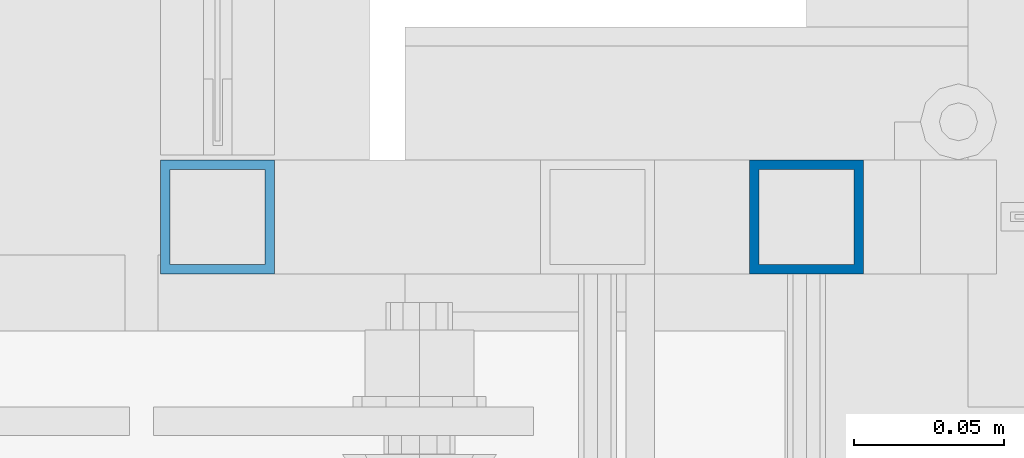
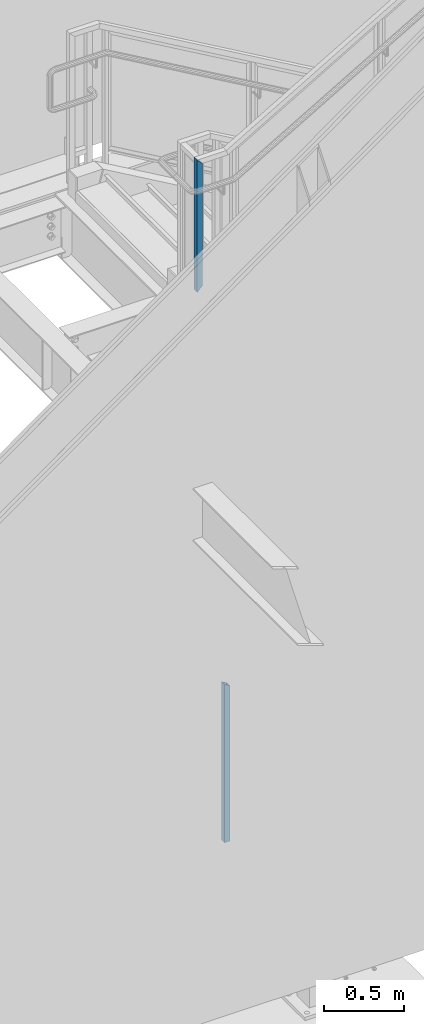
# One storey, part 372 of 1179: 2 columns, 2 elements without a shape of their own.
"""IFC2X3 building model written with IfcOpenShell, lengths in millimetres."""

from ifc_helpers import new_model, si_unit, frame, origin_with_axes, place, context, subcontext, project, spatial, faceted_brep, material, type_object, element, aggregate, save


model = new_model("IFC2X3")

# Units and contexts
model_context = context("Model", 3, precision=1e-05, world=origin_with_axes())
body_context = subcontext(model_context, "Body", "Model", "MODEL_VIEW")
ifc_project = project(units=[si_unit("LENGTHUNIT", "METRE", prefix="MILLI"), si_unit("AREAUNIT", "SQUARE_METRE"), si_unit("VOLUMEUNIT", "CUBIC_METRE"), si_unit("MASSUNIT", "GRAM", prefix="KILO"), si_unit("TIMEUNIT", "SECOND"), si_unit("PLANEANGLEUNIT", "RADIAN"), si_unit("SOLIDANGLEUNIT", "STERADIAN"), si_unit("THERMODYNAMICTEMPERATUREUNIT", "DEGREE_CELSIUS"), si_unit("LUMINOUSINTENSITYUNIT", "LUMEN")], contexts=[model_context])

# Site, building, storey
site_placement = place(None, origin_with_axes())
site = spatial("IfcSite", under=ifc_project, at=site_placement, CompositionType="ELEMENT")
building_placement = place(site_placement, origin_with_axes())
building = spatial("IfcBuilding", under=site, at=building_placement, Name="Undefined", CompositionType="ELEMENT")
storey_placement = place(building_placement, origin_with_axes())
storey = spatial("IfcBuildingStorey", under=building, at=storey_placement, Name="Undefined", CompositionType="ELEMENT", Elevation=0.0)

# Assembly, column
assembly_1_placement = place(storey_placement, origin_with_axes())
assembly_1 = element("IfcElementAssembly", 1, at=assembly_1_placement, inside=storey, Name="GUARDRAIL", AssemblyPlace="NOTDEFINED", PredefinedType="RIGID_FRAME")
ifc_material = material()
column_type = type_object("IfcColumnType", Name="HSS1-1/2X1-1/2X1/8", PredefinedType="NOTDEFINED")
column_1_placement = place(assembly_1_placement, frame((19303.9999992195, 39471.6000005027, 4330.699999235), z_axis=(-1.0, 0.0, 0.0), x_axis=(0.0, 0.0, 1.0)))
column_1 = element("IfcColumn", 2, at=column_1_placement, type_object=column_type, material=ifc_material, Name="POST", ObjectType="HSS1-1/2X1-1/2X1/8", context=body_context, shape_type="Brep", body=[
    faceted_brep([(15.874999282998, 15.874999282998, -15.8749992829999), (15.874999282998, -15.874999282998, -15.8749992829999), (955.675000716997, -15.874999282998, -15.8749992830017), (955.675000716997, 15.874999282998, -15.8749992830017), (-15.8749992830017, -15.874999282998, 15.8749992829999), (987.424999282998, -15.874999282998, 15.8749992830017), (-15.8749992830017, 15.874999282998, 15.8749992829999), (987.424999282998, 15.874999282998, 15.8749992830017), (19.0499999999993, 19.0499992349996, -19.0499992350015), (-19.0499992350015, 19.0499992350015, 19.0499992349996), (990.599999234998, 19.0499992350015, 19.0499992350015), (952.500000764997, 19.0499992350015, -19.0499992350015), (-19.0499992350015, -19.0499992350015, 19.0499992349996), (990.599999234998, -19.0499992350015, 19.0499992350015), (19.0499999999993, -19.0499992349996, -19.0499992350015), (952.500000764997, -19.0499992350015, -19.0499992350015)], [[[0, 1, 2, 3]], [[1, 4, 5, 2]], [[4, 6, 7, 5]], [[6, 0, 3, 7]], [[8, 9, 10, 11]], [[9, 12, 13, 10]], [[12, 14, 15, 13]], [[14, 8, 11, 15]], [[13, 15, 11, 10], [5, 7, 3, 2]], [[14, 12, 9, 8], [6, 4, 1, 0]]]),
])
aggregate(assembly_1, [column_1])

assembly_2_placement = place(storey_placement, origin_with_axes())
assembly_2 = element("IfcElementAssembly", 3, at=assembly_2_placement, inside=storey, Name="GUARDRAIL", AssemblyPlace="NOTDEFINED", PredefinedType="RIGID_FRAME")
column_2_placement = place(assembly_2_placement, frame((19500.8500004143, 39471.5999999818, 40.8806392036358), z_axis=(-1.0, 0.0, 0.0), x_axis=(0.0, 0.0, 1.0)))
column_2 = element("IfcColumn", 4, at=column_2_placement, type_object=column_type, material=ifc_material, Name="POST", ObjectType="HSS1-1/2X1-1/2X1/8", context=body_context, shape_type="Brep", body=[
    faceted_brep([(6.35000000000014, 15.874999282998, -15.8749992830017), (6.35000000000014, -15.874999282998, -15.8749992830017), (1193.24403468896, -15.874999282998, -15.8749992830017), (1193.24403468896, 15.874999282998, -15.8749992830017), (6.35000000000014, -15.874999282998, 15.8749992830017), (1211.54885347245, -15.874999282998, 15.8749992830017), (6.35000000000014, 15.874999282998, 15.8749992830017), (1211.54885347245, 15.874999282998, 15.8749992830017), (6.35000000000014, 19.0499992350015, -19.0499992350015), (6.35000000000014, 19.0499992350015, 19.0499992350015), (1213.3793354058, 19.0499992350015, 19.0499992350015), (1191.41355275561, 19.0499992350015, -19.0499992350015), (6.35000000000014, -19.0499992350015, 19.0499992350015), (1213.3793354058, -19.0499992350015, 19.0499992350015), (6.35000000000014, -19.0499992350015, -19.0499992350015), (1191.41355275561, -19.0499992350015, -19.0499992350015)], [[[0, 1, 2, 3]], [[1, 4, 5, 2]], [[4, 6, 7, 5]], [[6, 0, 3, 7]], [[8, 9, 10, 11]], [[9, 12, 13, 10]], [[12, 14, 15, 13]], [[14, 8, 11, 15]], [[13, 15, 11, 10], [5, 7, 3, 2]], [[14, 12, 9, 8], [6, 4, 1, 0]]]),
])
aggregate(assembly_2, [column_2])

save(model, "model.ifc")
